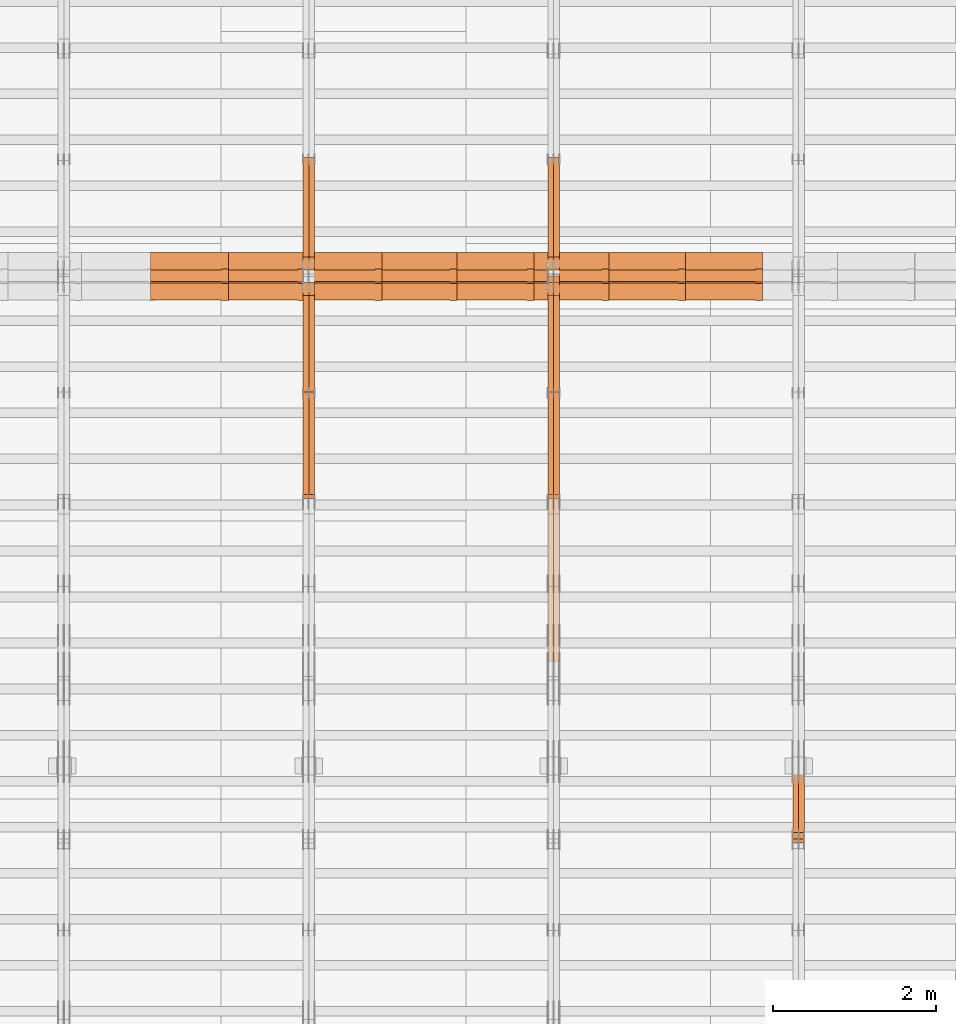
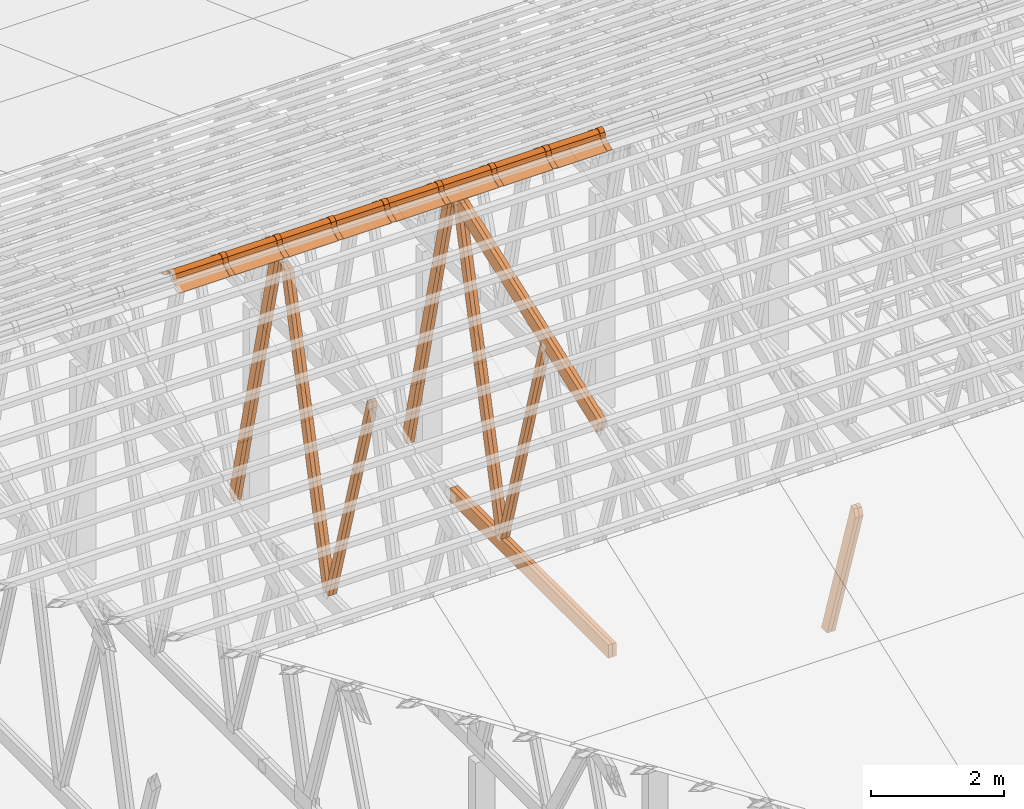
# One storey, part 50 of 189: 34 proxies.
"""IFC2X3 building model written with IfcOpenShell, lengths in millimetres."""

from ifc_helpers import new_model, entity, si_unit, converted_unit, derived_unit, direction, frame, frame_2d, origin, origin_2d_with_axis, place, context, subcontext, project, spatial, polyline, circle_curve, parameter, trimmed, segment, composite_curve, rectangle, outline, extrude, source, transform, mapped, material, type_object, type_shapes, element, save


model = new_model("IFC2X3")

# Units and contexts
model_context = context("Model", 3, precision=0.01, world=origin(), true_north=direction((6.12303176911189e-17, 1.0)))
body_context = subcontext(model_context, "Body", "Model", "MODEL_VIEW")
ifc_project = project(units=[si_unit("LENGTHUNIT", "METRE", prefix="MILLI"), si_unit("AREAUNIT", "SQUARE_METRE"), si_unit("VOLUMEUNIT", "CUBIC_METRE"), converted_unit("PLANEANGLEUNIT", "DEGREE", entity("IfcRatioMeasure", 0.0174532925199433), si_unit("PLANEANGLEUNIT", "RADIAN"), dimensions=[0, 0, 0, 0, 0, 0, 0]), si_unit("MASSUNIT", "GRAM", prefix="KILO"), derived_unit("MASSDENSITYUNIT", [(si_unit("MASSUNIT", "GRAM", prefix="KILO"), 1), (si_unit("LENGTHUNIT", "METRE"), -3)]), si_unit("TIMEUNIT", "SECOND"), si_unit("FREQUENCYUNIT", "HERTZ"), si_unit("THERMODYNAMICTEMPERATUREUNIT", "DEGREE_CELSIUS"), derived_unit("THERMALTRANSMITTANCEUNIT", [(si_unit("MASSUNIT", "GRAM", prefix="KILO"), 1), (si_unit("THERMODYNAMICTEMPERATUREUNIT", "KELVIN"), -1), (si_unit("TIMEUNIT", "SECOND"), -3)]), derived_unit("VOLUMETRICFLOWRATEUNIT", [(si_unit("LENGTHUNIT", "METRE"), 3), (si_unit("TIMEUNIT", "SECOND"), -1)]), si_unit("ELECTRICCURRENTUNIT", "AMPERE"), si_unit("ELECTRICVOLTAGEUNIT", "VOLT"), si_unit("POWERUNIT", "WATT"), si_unit("FORCEUNIT", "NEWTON"), si_unit("ILLUMINANCEUNIT", "LUX"), si_unit("LUMINOUSFLUXUNIT", "LUMEN"), si_unit("LUMINOUSINTENSITYUNIT", "CANDELA"), derived_unit("USERDEFINED", [(si_unit("MASSUNIT", "GRAM", prefix="KILO"), -1), (si_unit("LENGTHUNIT", "METRE"), -2), (si_unit("TIMEUNIT", "SECOND"), 3), (si_unit("LUMINOUSFLUXUNIT", "LUMEN"), 1)]), derived_unit("LINEARVELOCITYUNIT", [(si_unit("LENGTHUNIT", "METRE"), 1), (si_unit("TIMEUNIT", "SECOND"), -1)]), si_unit("PRESSUREUNIT", "PASCAL"), derived_unit("USERDEFINED", [(si_unit("LENGTHUNIT", "METRE"), -2), (si_unit("MASSUNIT", "GRAM", prefix="KILO"), 1), (si_unit("TIMEUNIT", "SECOND"), -2)])], contexts=[model_context])

# Site, building, storey
site_placement = place(None, origin())
site = spatial("IfcSite", under=ifc_project, at=site_placement, CompositionType="ELEMENT")
building_placement = place(site_placement, origin())
building = spatial("IfcBuilding", under=site, at=building_placement, CompositionType="ELEMENT")
storey_placement = place(building_placement, origin())
storey = spatial("IfcBuildingStorey", under=building, at=storey_placement, Name="Default", CompositionType="ELEMENT", Elevation=0.0)

# Proxies
ifc_material_1 = material(Name="IfcSurfaceStyle #209424")
building_element_proxy_type_1 = type_object("IfcBuildingElementProxyType", Name="T1-W4 209422", PredefinedType="NOTDEFINED", material=ifc_material_1)
shared_shape_1 = source(origin(), body_context, "Body", "SweptSolid", [
    extrude(outline(polyline([(-1688.09292256655, -85.0003489723785), (1071.44998120742, -85.0003489723785), (1178.19407811536, -0.00016040063201781), (1181.35435681367, 85.0004291726946), (-1742.9054935699, 85.0004291726946), (-1688.09292256655, -85.0003489723785)])), frame((1181.35446122976, 85.0007670757732, 0.0), z_axis=(0.0, 0.0, 1.0), x_axis=(-1.0, 0.0, 0.0)), (0.0, 0.0, 1.0), 69.9999999999998),
])
type_shapes(building_element_proxy_type_1, [shared_shape_1])
proxy_1_placement = place(building_placement, frame((39300.0, 7937.17021143291, 3028.170124945), z_axis=(-1.0, 0.0, 0.0), x_axis=(0.0, 0.306868406216492, -0.951751953644514)))
element("IfcBuildingElementProxy", 1, at=proxy_1_placement, inside=storey, type_object=building_element_proxy_type_1, material=ifc_material_1, Name="T1-W4", context=body_context, shape_type="MappedRepresentation", body=[
    mapped(shared_shape_1, transform((0.0, 0.0, 0.0), scale=1.0)),
])
ifc_material_2 = material(Name="IfcSurfaceStyle #209358")
building_element_proxy_type_2 = type_object("IfcBuildingElementProxyType", Name="T1-W4 209356", PredefinedType="NOTDEFINED", material=ifc_material_2)
shared_shape_2 = source(origin(), body_context, "Body", "SweptSolid", [
    extrude(outline(polyline([(-1688.09292256655, -85.0003489723785), (1071.44998120742, -85.0003489723785), (1178.19407811536, -0.00016040063201781), (1181.35435681367, 85.0004291726946), (-1742.9054935699, 85.0004291726946), (-1688.09292256655, -85.0003489723785)])), frame((1181.35446122976, 85.0007670757732, 0.0), z_axis=(0.0, 0.0, 1.0), x_axis=(-1.0, 0.0, 0.0)), (0.0, 0.0, 1.0), 69.9999999999998),
])
type_shapes(building_element_proxy_type_2, [shared_shape_2])
proxy_2_placement = place(building_placement, frame((39230.0, 7937.17021143291, 3028.170124945), z_axis=(-1.0, 0.0, 0.0), x_axis=(0.0, 0.306868406216492, -0.951751953644514)))
element("IfcBuildingElementProxy", 2, at=proxy_2_placement, inside=storey, type_object=building_element_proxy_type_2, material=ifc_material_2, Name="T1-W4", context=body_context, shape_type="MappedRepresentation", body=[
    mapped(shared_shape_2, transform((0.0, 0.0, 0.0), scale=1.0)),
])
ifc_material_3 = material(Name="IfcSurfaceStyle #194954")
building_element_proxy_type_3 = type_object("IfcBuildingElementProxyType", Name="T1-W5 194952", PredefinedType="NOTDEFINED", material=ifc_material_3)
shared_shape_3 = source(origin(), body_context, "Body", "SweptSolid", [
    extrude(outline(polyline([(-3233.61216530572, -72.4999091305202), (2153.79187521892, -72.4999091305202), (2171.36968478227, -7.18521572819375e-05), (2045.62106208646, 72.4999450565989), (-3137.17045678193, 72.4999450565989), (-3233.61216530572, -72.4999091305202)])), frame((2171.36968478227, 72.500192121173, 0.0), z_axis=(0.0, 0.0, 1.0), x_axis=(-1.0, 0.0, 0.0)), (0.0, 0.0, 1.0), 69.9999999999997),
])
type_shapes(building_element_proxy_type_3, [shared_shape_3])
proxy_3_placement = place(building_placement, frame((36300.0, 13261.0146935344, 262.082919891325), z_axis=(-1.0, 0.0, 0.0), x_axis=(0.0, 0.235625623344066, 0.97184389982328)))
element("IfcBuildingElementProxy", 3, at=proxy_3_placement, inside=storey, type_object=building_element_proxy_type_3, material=ifc_material_3, Name="T1-W5", context=body_context, shape_type="MappedRepresentation", body=[
    mapped(shared_shape_3, transform((0.0, 0.0, 0.0), scale=1.0)),
])
ifc_material_4 = material(Name="IfcSurfaceStyle #194888")
building_element_proxy_type_4 = type_object("IfcBuildingElementProxyType", Name="T1-W5 194886", PredefinedType="NOTDEFINED", material=ifc_material_4)
shared_shape_4 = source(origin(), body_context, "Body", "SweptSolid", [
    extrude(outline(polyline([(-3233.61216530572, -72.4999091305202), (2153.79187521892, -72.4999091305202), (2171.36968478227, -7.18521572819375e-05), (2045.62106208646, 72.4999450565989), (-3137.17045678193, 72.4999450565989), (-3233.61216530572, -72.4999091305202)])), frame((2171.36968478227, 72.500192121173, 0.0), z_axis=(0.0, 0.0, 1.0), x_axis=(-1.0, 0.0, 0.0)), (0.0, 0.0, 1.0), 69.9999999999997),
])
type_shapes(building_element_proxy_type_4, [shared_shape_4])
proxy_4_placement = place(building_placement, frame((36230.0, 13261.0146935344, 262.082919891325), z_axis=(-1.0, 0.0, 0.0), x_axis=(0.0, 0.235625623344066, 0.97184389982328)))
element("IfcBuildingElementProxy", 4, at=proxy_4_placement, inside=storey, type_object=building_element_proxy_type_4, material=ifc_material_4, Name="T1-W5", context=body_context, shape_type="MappedRepresentation", body=[
    mapped(shared_shape_4, transform((0.0, 0.0, 0.0), scale=1.0)),
])
ifc_material_5 = material(Name="IfcSurfaceStyle #194822")
building_element_proxy_type_5 = type_object("IfcBuildingElementProxyType", Name="T1-W5 194820", PredefinedType="NOTDEFINED", material=ifc_material_5)
shared_shape_5 = source(origin(), body_context, "Body", "SweptSolid", [
    extrude(outline(polyline([(-3137.17045678193, -72.5002081306407), (2045.62106208646, -72.5002081306408), (2171.36968478227, 5.58426931168476e-05), (2153.79187521892, 72.5001802092942), (-3233.61216530572, 72.5001802092942), (-3137.17045678193, -72.5002081306407)])), frame((2171.36968478227, 72.5001802092942, 0.0), z_axis=(0.0, 0.0, 1.0), x_axis=(-1.0, 0.0, 0.0)), (0.0, 0.0, 1.0), 69.9999999999997),
])
type_shapes(building_element_proxy_type_5, [shared_shape_5])
proxy_5_placement = place(building_placement, frame((36300.0, 16098.0675635854, 227.917113003597), z_axis=(-1.0, 0.0, 0.0), x_axis=(0.0, -0.235625623344066, 0.971843899823279)))
element("IfcBuildingElementProxy", 5, at=proxy_5_placement, inside=storey, type_object=building_element_proxy_type_5, material=ifc_material_5, Name="T1-W5", context=body_context, shape_type="MappedRepresentation", body=[
    mapped(shared_shape_5, transform((0.0, 0.0, 0.0), scale=1.0)),
])
ifc_material_6 = material(Name="IfcSurfaceStyle #194756")
building_element_proxy_type_6 = type_object("IfcBuildingElementProxyType", Name="T1-W5 194754", PredefinedType="NOTDEFINED", material=ifc_material_6)
shared_shape_6 = source(origin(), body_context, "Body", "SweptSolid", [
    extrude(outline(polyline([(-3137.17045678193, -72.5002081306407), (2045.62106208646, -72.5002081306408), (2171.36968478227, 5.58426931168476e-05), (2153.79187521892, 72.5001802092942), (-3233.61216530572, 72.5001802092942), (-3137.17045678193, -72.5002081306407)])), frame((2171.36968478227, 72.5001802092942, 0.0), z_axis=(0.0, 0.0, 1.0), x_axis=(-1.0, 0.0, 0.0)), (0.0, 0.0, 1.0), 69.9999999999997),
])
type_shapes(building_element_proxy_type_6, [shared_shape_6])
proxy_6_placement = place(building_placement, frame((36230.0, 16098.0675635854, 227.917113003597), z_axis=(-1.0, 0.0, 0.0), x_axis=(0.0, -0.235625623344066, 0.971843899823279)))
element("IfcBuildingElementProxy", 6, at=proxy_6_placement, inside=storey, type_object=building_element_proxy_type_6, material=ifc_material_6, Name="T1-W5", context=body_context, shape_type="MappedRepresentation", body=[
    mapped(shared_shape_6, transform((0.0, 0.0, 0.0), scale=1.0)),
])
ifc_material_7 = material(Name="IfcSurfaceStyle #194690")
building_element_proxy_type_7 = type_object("IfcBuildingElementProxyType", Name="T1-W6 194688", PredefinedType="NOTDEFINED", material=ifc_material_7)
shared_shape_7 = source(origin(), body_context, "Body", "SweptSolid", [
    extrude(outline(polyline([(-2640.84340836012, -47.4996765865792), (1711.12245024294, -47.4996765865792), (1797.68490303083, -9.57690019346202e-05), (1800.72595169379, 47.4997244710801), (-2668.68989660745, 47.4997244710801), (-2640.84340836012, -47.4996765865792)])), frame((1800.72595169379, 47.5003009358159, 0.0), z_axis=(0.0, 0.0, 1.0), x_axis=(-1.0, 0.0, 0.0)), (0.0, 0.0, 1.0), 69.9999999999997),
])
type_shapes(building_element_proxy_type_7, [shared_shape_7])
proxy_7_placement = place(building_placement, frame((36300.0, 12074.2896156894, 4533.9586582452), z_axis=(-1.0, 0.0, 0.0), x_axis=(0.0, 0.28128598310461, -0.959623986626467)))
element("IfcBuildingElementProxy", 7, at=proxy_7_placement, inside=storey, type_object=building_element_proxy_type_7, material=ifc_material_7, Name="T1-W6", context=body_context, shape_type="MappedRepresentation", body=[
    mapped(shared_shape_7, transform((0.0, 0.0, 0.0), scale=1.0)),
])
ifc_material_8 = material(Name="IfcSurfaceStyle #194624")
building_element_proxy_type_8 = type_object("IfcBuildingElementProxyType", Name="T1-W6 194622", PredefinedType="NOTDEFINED", material=ifc_material_8)
shared_shape_8 = source(origin(), body_context, "Body", "SweptSolid", [
    extrude(outline(polyline([(-2640.84340836012, -47.4996765865792), (1711.12245024294, -47.4996765865792), (1797.68490303083, -9.57690019346202e-05), (1800.72595169379, 47.4997244710801), (-2668.68989660745, 47.4997244710801), (-2640.84340836012, -47.4996765865792)])), frame((1800.72595169379, 47.5003009358159, 0.0), z_axis=(0.0, 0.0, 1.0), x_axis=(-1.0, 0.0, 0.0)), (0.0, 0.0, 1.0), 69.9999999999997),
])
type_shapes(building_element_proxy_type_8, [shared_shape_8])
proxy_8_placement = place(building_placement, frame((36230.0, 12074.2896156894, 4533.9586582452), z_axis=(-1.0, 0.0, 0.0), x_axis=(0.0, 0.28128598310461, -0.959623986626467)))
element("IfcBuildingElementProxy", 8, at=proxy_8_placement, inside=storey, type_object=building_element_proxy_type_8, material=ifc_material_8, Name="T1-W6", context=body_context, shape_type="MappedRepresentation", body=[
    mapped(shared_shape_8, transform((0.0, 0.0, 0.0), scale=1.0)),
])
ifc_material_9 = material(Name="IfcSurfaceStyle #190670")
building_element_proxy_type_9 = type_object("IfcBuildingElementProxyType", Name="T1-B3 190668", PredefinedType="NOTDEFINED", material=ifc_material_9)
shared_shape_9 = source(origin(), body_context, "Body", "SweptSolid", [
    extrude(rectangle(XDim=4751.0283203125, YDim=245.000000000001, at=origin_2d_with_axis()), frame((2375.51416015625, 122.5, 0.0), z_axis=(0.0, 0.0, 1.0), x_axis=(-1.0, 0.0, 0.0)), (0.0, 0.0, 1.0), 69.9999999999997),
])
type_shapes(building_element_proxy_type_9, [shared_shape_9])
proxy_9_placement = place(building_placement, frame((36300.0, 10029.23046875, 245.0), z_axis=(-1.0, 0.0, 0.0), x_axis=(0.0, 1.0, 0.0)))
element("IfcBuildingElementProxy", 9, at=proxy_9_placement, inside=storey, type_object=building_element_proxy_type_9, material=ifc_material_9, Name="T1-B3", context=body_context, shape_type="MappedRepresentation", body=[
    mapped(shared_shape_9, transform((0.0, 0.0, 0.0), scale=1.0)),
])
ifc_material_10 = material(Name="IfcSurfaceStyle #190613")
building_element_proxy_type_10 = type_object("IfcBuildingElementProxyType", Name="T1-B3 190611", PredefinedType="NOTDEFINED", material=ifc_material_10)
shared_shape_10 = source(origin(), body_context, "Body", "SweptSolid", [
    extrude(rectangle(XDim=4751.0283203125, YDim=245.000000000001, at=origin_2d_with_axis()), frame((2375.51416015625, 122.5, 0.0), z_axis=(0.0, 0.0, 1.0), x_axis=(-1.0, 0.0, 0.0)), (0.0, 0.0, 1.0), 69.9999999999997),
])
type_shapes(building_element_proxy_type_10, [shared_shape_10])
proxy_10_placement = place(building_placement, frame((36230.0, 10029.23046875, 245.0), z_axis=(-1.0, 0.0, 0.0), x_axis=(0.0, 1.0, 0.0)))
element("IfcBuildingElementProxy", 10, at=proxy_10_placement, inside=storey, type_object=building_element_proxy_type_10, material=ifc_material_10, Name="T1-B3", context=body_context, shape_type="MappedRepresentation", body=[
    mapped(shared_shape_10, transform((0.0, 0.0, 0.0), scale=1.0)),
])
ifc_material_11 = material(Name="IfcSurfaceStyle #190082")
building_element_proxy_type_11 = type_object("IfcBuildingElementProxyType", Name="T1-T3 190080", PredefinedType="NOTDEFINED", material=ifc_material_11)
shared_shape_11 = source(origin(), body_context, "Body", "SweptSolid", [
    extrude(outline(polyline([(-2341.64890001385, -122.499972785692), (2386.23525922045, -122.499972785692), (2297.06252495753, 122.499972785692), (-2341.64888416412, 122.499972785692), (-2341.64890001385, -122.499972785692)])), frame((2386.23525922045, 122.499973888764, 0.0), z_axis=(0.0, 0.0, 1.0), x_axis=(-1.0, 0.0, 0.0)), (0.0, 0.0, 1.0), 69.9999999999997),
])
type_shapes(building_element_proxy_type_11, [shared_shape_11])
proxy_11_placement = place(building_placement, frame((36300.0, 14833.7949607394, 5538.33627266055), z_axis=(-1.0, 0.0, 0.0), x_axis=(0.0, -0.939692620785908, -0.342020143325669)))
element("IfcBuildingElementProxy", 11, at=proxy_11_placement, inside=storey, type_object=building_element_proxy_type_11, material=ifc_material_11, Name="T1-T3", context=body_context, shape_type="MappedRepresentation", body=[
    mapped(shared_shape_11, transform((0.0, 0.0, 0.0), scale=1.0)),
])
ifc_material_12 = material(Name="IfcSurfaceStyle #190025")
building_element_proxy_type_12 = type_object("IfcBuildingElementProxyType", Name="T1-T3 190023", PredefinedType="NOTDEFINED", material=ifc_material_12)
shared_shape_12 = source(origin(), body_context, "Body", "SweptSolid", [
    extrude(outline(polyline([(-2341.64890001385, -122.499972785692), (2386.23525922045, -122.499972785692), (2297.06252495753, 122.499972785692), (-2341.64888416412, 122.499972785692), (-2341.64890001385, -122.499972785692)])), frame((2386.23525922045, 122.499973888764, 0.0), z_axis=(0.0, 0.0, 1.0), x_axis=(-1.0, 0.0, 0.0)), (0.0, 0.0, 1.0), 69.9999999999997),
])
type_shapes(building_element_proxy_type_12, [shared_shape_12])
proxy_12_placement = place(building_placement, frame((36230.0, 14833.7949607394, 5538.33627266055), z_axis=(-1.0, 0.0, 0.0), x_axis=(0.0, -0.939692620785908, -0.342020143325669)))
element("IfcBuildingElementProxy", 12, at=proxy_12_placement, inside=storey, type_object=building_element_proxy_type_12, material=ifc_material_12, Name="T1-T3", context=body_context, shape_type="MappedRepresentation", body=[
    mapped(shared_shape_12, transform((0.0, 0.0, 0.0), scale=1.0)),
])
ifc_material_13 = material(Name="IfcSurfaceStyle #179164")
building_element_proxy_type_13 = type_object("IfcBuildingElementProxyType", Name="T1-W5 179162", PredefinedType="NOTDEFINED", material=ifc_material_13)
shared_shape_13 = source(origin(), body_context, "Body", "SweptSolid", [
    extrude(outline(polyline([(-3233.61216530572, -72.4999091305202), (2153.79187521892, -72.4999091305202), (2171.36968478227, -7.18521572819375e-05), (2045.62106208646, 72.4999450565989), (-3137.17045678193, 72.4999450565989), (-3233.61216530572, -72.4999091305202)])), frame((2171.36968478227, 72.500192121173, 0.0), z_axis=(0.0, 0.0, 1.0), x_axis=(-1.0, 0.0, 0.0)), (0.0, 0.0, 1.0), 69.9999999999997),
])
type_shapes(building_element_proxy_type_13, [shared_shape_13])
proxy_13_placement = place(building_placement, frame((33300.0, 13261.0146935344, 262.082919891325), z_axis=(-1.0, 0.0, 0.0), x_axis=(0.0, 0.235625623344066, 0.97184389982328)))
element("IfcBuildingElementProxy", 13, at=proxy_13_placement, inside=storey, type_object=building_element_proxy_type_13, material=ifc_material_13, Name="T1-W5", context=body_context, shape_type="MappedRepresentation", body=[
    mapped(shared_shape_13, transform((0.0, 0.0, 0.0), scale=1.0)),
])
ifc_material_14 = material(Name="IfcSurfaceStyle #179098")
building_element_proxy_type_14 = type_object("IfcBuildingElementProxyType", Name="T1-W5 179096", PredefinedType="NOTDEFINED", material=ifc_material_14)
shared_shape_14 = source(origin(), body_context, "Body", "SweptSolid", [
    extrude(outline(polyline([(-3233.61216530572, -72.4999091305202), (2153.79187521892, -72.4999091305202), (2171.36968478227, -7.18521572819375e-05), (2045.62106208646, 72.4999450565989), (-3137.17045678193, 72.4999450565989), (-3233.61216530572, -72.4999091305202)])), frame((2171.36968478227, 72.500192121173, 0.0), z_axis=(0.0, 0.0, 1.0), x_axis=(-1.0, 0.0, 0.0)), (0.0, 0.0, 1.0), 69.9999999999997),
])
type_shapes(building_element_proxy_type_14, [shared_shape_14])
proxy_14_placement = place(building_placement, frame((33230.0, 13261.0146935344, 262.082919891325), z_axis=(-1.0, 0.0, 0.0), x_axis=(0.0, 0.235625623344066, 0.97184389982328)))
element("IfcBuildingElementProxy", 14, at=proxy_14_placement, inside=storey, type_object=building_element_proxy_type_14, material=ifc_material_14, Name="T1-W5", context=body_context, shape_type="MappedRepresentation", body=[
    mapped(shared_shape_14, transform((0.0, 0.0, 0.0), scale=1.0)),
])
ifc_material_15 = material(Name="IfcSurfaceStyle #179032")
building_element_proxy_type_15 = type_object("IfcBuildingElementProxyType", Name="T1-W5 179030", PredefinedType="NOTDEFINED", material=ifc_material_15)
shared_shape_15 = source(origin(), body_context, "Body", "SweptSolid", [
    extrude(outline(polyline([(-3137.17045678193, -72.5002081306407), (2045.62106208646, -72.5002081306408), (2171.36968478227, 5.58426931168476e-05), (2153.79187521892, 72.5001802092942), (-3233.61216530572, 72.5001802092942), (-3137.17045678193, -72.5002081306407)])), frame((2171.36968478227, 72.5001802092942, 0.0), z_axis=(0.0, 0.0, 1.0), x_axis=(-1.0, 0.0, 0.0)), (0.0, 0.0, 1.0), 69.9999999999997),
])
type_shapes(building_element_proxy_type_15, [shared_shape_15])
proxy_15_placement = place(building_placement, frame((33300.0, 16098.0675635854, 227.917113003597), z_axis=(-1.0, 0.0, 0.0), x_axis=(0.0, -0.235625623344066, 0.971843899823279)))
element("IfcBuildingElementProxy", 15, at=proxy_15_placement, inside=storey, type_object=building_element_proxy_type_15, material=ifc_material_15, Name="T1-W5", context=body_context, shape_type="MappedRepresentation", body=[
    mapped(shared_shape_15, transform((0.0, 0.0, 0.0), scale=1.0)),
])
ifc_material_16 = material(Name="IfcSurfaceStyle #178966")
building_element_proxy_type_16 = type_object("IfcBuildingElementProxyType", Name="T1-W5 178964", PredefinedType="NOTDEFINED", material=ifc_material_16)
shared_shape_16 = source(origin(), body_context, "Body", "SweptSolid", [
    extrude(outline(polyline([(-3137.17045678193, -72.5002081306407), (2045.62106208646, -72.5002081306408), (2171.36968478227, 5.58426931168476e-05), (2153.79187521892, 72.5001802092942), (-3233.61216530572, 72.5001802092942), (-3137.17045678193, -72.5002081306407)])), frame((2171.36968478227, 72.5001802092942, 0.0), z_axis=(0.0, 0.0, 1.0), x_axis=(-1.0, 0.0, 0.0)), (0.0, 0.0, 1.0), 69.9999999999997),
])
type_shapes(building_element_proxy_type_16, [shared_shape_16])
proxy_16_placement = place(building_placement, frame((33230.0, 16098.0675635854, 227.917113003597), z_axis=(-1.0, 0.0, 0.0), x_axis=(0.0, -0.235625623344066, 0.971843899823279)))
element("IfcBuildingElementProxy", 16, at=proxy_16_placement, inside=storey, type_object=building_element_proxy_type_16, material=ifc_material_16, Name="T1-W5", context=body_context, shape_type="MappedRepresentation", body=[
    mapped(shared_shape_16, transform((0.0, 0.0, 0.0), scale=1.0)),
])
ifc_material_17 = material(Name="IfcSurfaceStyle #178900")
building_element_proxy_type_17 = type_object("IfcBuildingElementProxyType", Name="T1-W6 178898", PredefinedType="NOTDEFINED", material=ifc_material_17)
shared_shape_17 = source(origin(), body_context, "Body", "SweptSolid", [
    extrude(outline(polyline([(-2640.84340836012, -47.4996765865792), (1711.12245024294, -47.4996765865792), (1797.68490303083, -9.57690019346202e-05), (1800.72595169379, 47.4997244710801), (-2668.68989660745, 47.4997244710801), (-2640.84340836012, -47.4996765865792)])), frame((1800.72595169379, 47.5003009358159, 0.0), z_axis=(0.0, 0.0, 1.0), x_axis=(-1.0, 0.0, 0.0)), (0.0, 0.0, 1.0), 69.9999999999997),
])
type_shapes(building_element_proxy_type_17, [shared_shape_17])
proxy_17_placement = place(building_placement, frame((33300.0, 12074.2896156894, 4533.9586582452), z_axis=(-1.0, 0.0, 0.0), x_axis=(0.0, 0.28128598310461, -0.959623986626467)))
element("IfcBuildingElementProxy", 17, at=proxy_17_placement, inside=storey, type_object=building_element_proxy_type_17, material=ifc_material_17, Name="T1-W6", context=body_context, shape_type="MappedRepresentation", body=[
    mapped(shared_shape_17, transform((0.0, 0.0, 0.0), scale=1.0)),
])
ifc_material_18 = material(Name="IfcSurfaceStyle #178834")
building_element_proxy_type_18 = type_object("IfcBuildingElementProxyType", Name="T1-W6 178832", PredefinedType="NOTDEFINED", material=ifc_material_18)
shared_shape_18 = source(origin(), body_context, "Body", "SweptSolid", [
    extrude(outline(polyline([(-2640.84340836012, -47.4996765865792), (1711.12245024294, -47.4996765865792), (1797.68490303083, -9.57690019346202e-05), (1800.72595169379, 47.4997244710801), (-2668.68989660745, 47.4997244710801), (-2640.84340836012, -47.4996765865792)])), frame((1800.72595169379, 47.5003009358159, 0.0), z_axis=(0.0, 0.0, 1.0), x_axis=(-1.0, 0.0, 0.0)), (0.0, 0.0, 1.0), 69.9999999999997),
])
type_shapes(building_element_proxy_type_18, [shared_shape_18])
proxy_18_placement = place(building_placement, frame((33230.0, 12074.2896156894, 4533.9586582452), z_axis=(-1.0, 0.0, 0.0), x_axis=(0.0, 0.28128598310461, -0.959623986626467)))
element("IfcBuildingElementProxy", 18, at=proxy_18_placement, inside=storey, type_object=building_element_proxy_type_18, material=ifc_material_18, Name="T1-W6", context=body_context, shape_type="MappedRepresentation", body=[
    mapped(shared_shape_18, transform((0.0, 0.0, 0.0), scale=1.0)),
])
ifc_material_19 = material()
building_element_proxy_type_19 = type_object("IfcBuildingElementProxyType", Name="P75", PredefinedType="NOTDEFINED", material=ifc_material_19)
shared_shape_19 = source(origin(), body_context, "Body", "SweptSolid", [
    extrude(outline(composite_curve([segment(polyline([(-69.4623915065845, -4.60763114971976), (47.4521071665907, -4.60763114971981)]), True, "CONTINUOUS"), segment(trimmed(circle_curve(frame_2d((119.940978060963, 14.6372018310859), x_axis=(-0.966518278591622, -0.256597773077395)), 75.0), [parameter(6.61555373744412e-13)], [parameter(180.0)], True, "PARAMETER"), True, "CONTINUOUS"), segment(polyline([(192.429848955335, 33.882034811891), (182.764666169419, 31.3160570811166)]), True, "CONTINUOUS"), segment(trimmed(circle_curve(frame_2d((119.940978060963, 14.6372018310859), x_axis=(-0.966518278591622, -0.256597773077395)), 65.0), [parameter(1.06866637297174e-12)], [parameter(180.0)], True, "PARAMETER"), False, "CONTINUOUS"), segment(polyline([(57.1172899525073, -2.04165341894578), (47.4521071665911, 5.39236885028051)]), True, "CONTINUOUS"), segment(polyline([(47.4521071665911, 5.39236885028052), (-70.7672243976422, 5.39236885028094)]), True, "CONTINUOUS"), segment(polyline([(-70.7672243976422, 5.39236885028094), (-194.776190618495, -27.5303655446341)]), True, "CONTINUOUS"), segment(polyline([(-194.776190618495, -27.5303655446341), (-192.210212887721, -37.1955483305503)]), True, "CONTINUOUS"), segment(polyline([(-192.210212887721, -37.1955483305503), (-69.4623915065845, -4.60763114971974)]), True, "CONTINUOUS")], self_intersect=False)), frame((0.0, 106.775760402721, -56.5599052870917), z_axis=(1.0, 0.0, 0.0), x_axis=(0.0, -0.820468487122275, 0.571691754041709)), (0.0, 0.0, 1.0), 867.000000000001),
    extrude(outline(composite_curve([segment(polyline([(62.2906866429439, -18.428943356533), (189.290686642944, -18.428943356533)]), True, "CONTINUOUS"), segment(polyline([(189.290686642944, -18.428943356533), (189.290686642944, -8.42894335653292)]), True, "CONTINUOUS"), segment(polyline([(189.290686642944, -8.42894335653292), (62.2906866429439, -8.42894335653294)]), True, "CONTINUOUS"), segment(polyline([(62.2906866429439, -8.42894335653294), (-41.0348065006093, 19.0026034957362)]), True, "CONTINUOUS"), segment(trimmed(circle_curve(frame_2d((-125.709313357056, 11.5710566434651), x_axis=(1.0, 0.0)), 85.0), [parameter(5.01577186738723)], [parameter(180.0)], True, "PARAMETER"), True, "CONTINUOUS"), segment(polyline([(-210.709313357056, 11.5710566434656), (-200.709313357056, 11.5710566434656)]), True, "CONTINUOUS"), segment(trimmed(circle_curve(frame_2d((-125.709313357056, 11.5710566434651), x_axis=(1.0, 0.0)), 75.0), [parameter(3.05333249420498e-13)], [parameter(180.0)], True, "PARAMETER"), False, "CONTINUOUS"), segment(polyline([(-50.7093133570542, 11.5710566434655), (62.290686642944, -18.4289433565322)]), True, "CONTINUOUS")], self_intersect=False)), frame((867.0, 114.170579674061, -53.8683539143053), z_axis=(1.0, 0.0, 0.0), x_axis=(0.0, 0.939692620785914, -0.342020143325653)), (0.0, 0.0, 1.0), 86.9999999999998),
])
type_shapes(building_element_proxy_type_19, [shared_shape_19])
for number, where, name in (
    (19, (37832.9353253273, 14755.0000438631, 5865.69618295448), "P75, generic model20:P75"),
    (20, (36892.9353253273, 14755.0000438631, 5865.69618295448), "P75, generic model20:P75"),
    (21, (35952.9353253273, 14755.0000438631, 5865.69618295448), "P75, generic model20:P75"),
    (22, (35032.9353253273, 14755.0000438631, 5865.69618295448), "P75, generic model20:P75"),
    (23, (34092.9353253273, 14755.0000438631, 5865.69618295448), "P75, generic model20:P75"),
    (24, (33172.9353253273, 14755.0000438631, 5865.69618295448), "P75, generic model20:P75"),
    (25, (32232.9353253273, 14755.0000438631, 5865.69618295448), "P75, generic model20:P75"),
    (26, (31292.9353253273, 14755.0000438631, 5865.69618295448), "P75, generic model20:P75"),
):
    element("IfcBuildingElementProxy", number, at=place(storey_placement, frame(where)), inside=storey, type_object=building_element_proxy_type_19, material=ifc_material_19, Name=name, ObjectType="P75, generic model20:P75", context=body_context, shape_type="MappedRepresentation", body=[
        mapped(shared_shape_19, transform((0.0, 0.0, 0.0), scale=1.0)),
    ])
building_element_proxy_type_20 = type_object("IfcBuildingElementProxyType", Name="P75", PredefinedType="NOTDEFINED", material=ifc_material_19)
shared_shape_20 = source(origin(), body_context, "Body", "SweptSolid", [
    extrude(outline(composite_curve([segment(polyline([(68.3189789579817, 13.3705352460084), (195.318978957982, 13.3705352460084)]), True, "CONTINUOUS"), segment(polyline([(195.318978957982, 13.3705352460084), (195.318978957982, 23.3705352460084)]), True, "CONTINUOUS"), segment(polyline([(195.318978957982, 23.3705352460084), (67.014146066922, 23.3705352460088)]), True, "CONTINUOUS"), segment(polyline([(67.014146066922, 23.3705352460088), (-47.2469987727929, -6.96428196807339)]), True, "CONTINUOUS"), segment(polyline([(-47.2469987727929, -6.96428196807339), (-54.6810210420187, -16.62946475399)]), True, "CONTINUOUS"), segment(trimmed(circle_curve(frame_2d((-119.681021042019, -16.6294647539896), x_axis=(1.0, 0.0)), 65.0), [parameter(180.0)], [parameter(359.999999999999)], True, "PARAMETER"), False, "CONTINUOUS"), segment(polyline([(-184.681021042019, -16.6294647539905), (-194.681021042019, -16.6294647539901)]), True, "CONTINUOUS"), segment(trimmed(circle_curve(frame_2d((-119.681021042019, -16.6294647539896), x_axis=(1.0, 0.0)), 75.0), [parameter(180.0)], [parameter(359.999999999999)], True, "PARAMETER"), True, "CONTINUOUS"), segment(polyline([(-44.6810210420183, -16.6294647539898), (68.3189789579816, 13.3705352460083)]), True, "CONTINUOUS")], self_intersect=False)), frame((0.0, -106.775760402721, -56.5599052870916), z_axis=(1.0, 0.0, 0.0), x_axis=(0.0, -0.939692620785914, -0.342020143325654)), (0.0, 0.0, 1.0), 867.000000000001),
    extrude(outline(composite_curve([segment(polyline([(-64.9339130518847, 1.82825913317695), (-187.681734433021, -30.7596580476538)]), True, "CONTINUOUS"), segment(polyline([(-187.681734433021, -30.7596580476538), (-185.115756702247, -40.4248408335702)]), True, "CONTINUOUS"), segment(polyline([(-185.115756702247, -40.4248408335702), (-62.3679353211107, -7.83692365273935)]), True, "CONTINUOUS"), segment(polyline([(-62.3679353211107, -7.83692365273935), (44.5369162809878, -7.83692365273935)]), True, "CONTINUOUS"), segment(trimmed(circle_curve(frame_2d((124.469456515662, 21.0730921139827), x_axis=(-0.966518278591636, -0.256597773077402)), 85.0), [parameter(5.01577186738723)], [parameter(180.0)], True, "PARAMETER"), True, "CONTINUOUS"), segment(polyline([(206.623510195951, 42.8839028255618), (196.958327410034, 40.3179250947878)]), True, "CONTINUOUS"), segment(trimmed(circle_curve(frame_2d((124.469456515662, 21.0730921139827), x_axis=(-0.966518278591636, -0.256597773077402)), 75.0), [parameter(3.05333249420498e-13)], [parameter(180.0)], True, "PARAMETER"), False, "CONTINUOUS"), segment(polyline([(51.9805856212887, 1.82825913317622), (-64.9339130518846, 1.82825913317621)]), True, "CONTINUOUS")], self_intersect=False)), frame((867.0, -114.170579674061, -53.868353914305), z_axis=(-1.0, 0.0, 0.0), x_axis=(0.0, 0.820468487122275, 0.571691754041709)), (0.0, 0.0, -1.0), 86.9999999999998),
])
type_shapes(building_element_proxy_type_20, [shared_shape_20])
for number, where, name in (
    (27, (37832.9353253273, 14745.0000384613, 5850.69618295448), "P75, generic model20:P75"),
    (28, (36892.9353253273, 14745.0000384613, 5850.69618295448), "P75, generic model20:P75"),
    (29, (35952.9353253273, 14745.0000384613, 5850.69618295448), "P75, generic model20:P75"),
    (30, (35032.9353253273, 14745.0000384614, 5850.69618295448), "P75, generic model20:P75"),
    (31, (34092.9353253273, 14745.0000384614, 5850.69618295448), "P75, generic model20:P75"),
    (32, (33172.9353253273, 14745.0000384614, 5850.69618295448), "P75, generic model20:P75"),
    (33, (32232.9353253273, 14745.0000384614, 5850.69618295448), "P75, generic model20:P75"),
    (34, (31292.9353253273, 14745.0000384614, 5850.69618295448), "P75, generic model20:P75"),
):
    element("IfcBuildingElementProxy", number, at=place(storey_placement, frame(where)), inside=storey, type_object=building_element_proxy_type_20, material=ifc_material_19, Name=name, ObjectType="P75, generic model20:P75", context=body_context, shape_type="MappedRepresentation", body=[
        mapped(shared_shape_20, transform((0.0, 0.0, 0.0), scale=1.0)),
    ])

save(model, "model.ifc")
